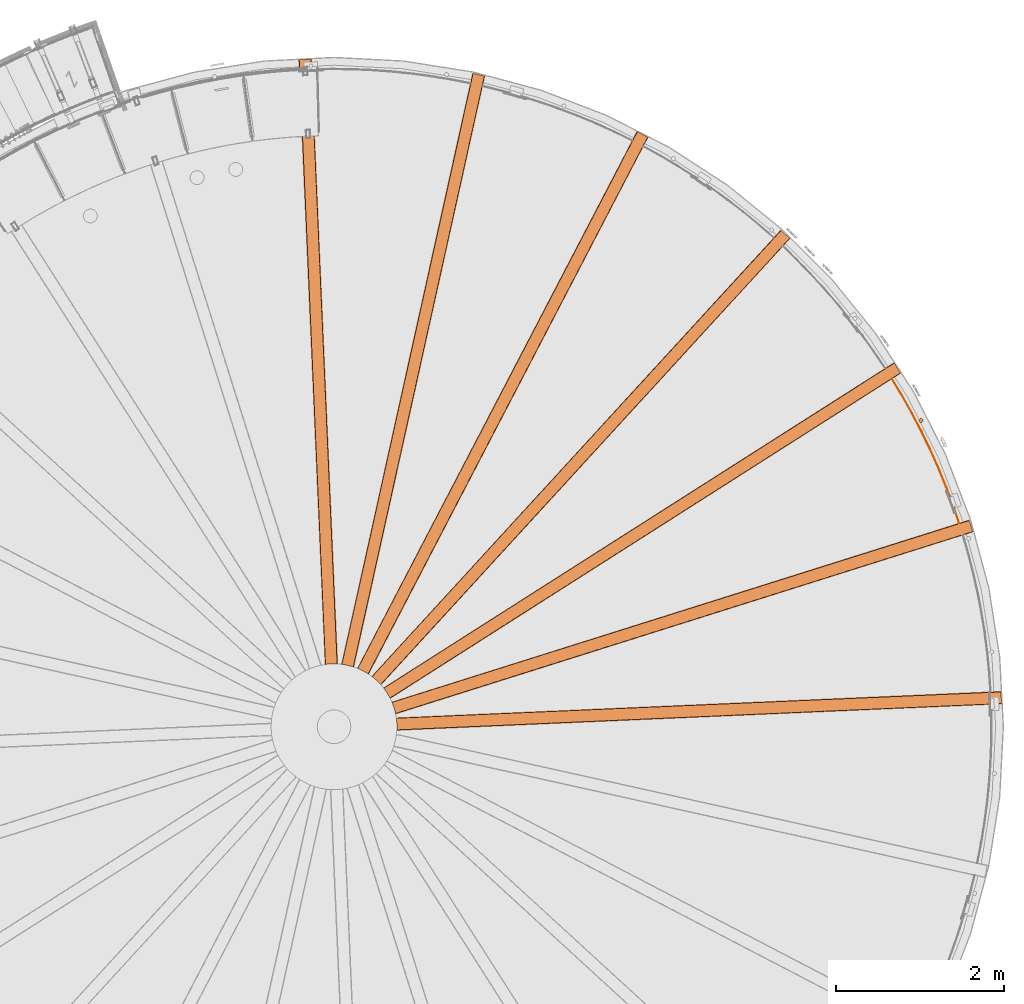
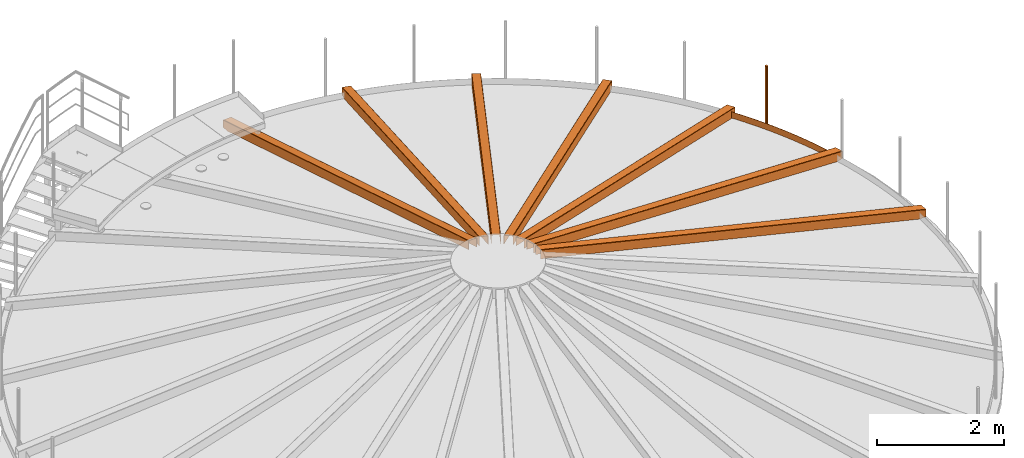
# One storey, part 40 of 126: 9 proxies.
"""IFC2X3 building model written with IfcOpenShell, lengths in millimetres."""

from ifc_helpers import new_model, si_unit, origin, origin_with_axes, place, context, project, spatial, faceted_brep, material, element, save


model = new_model("IFC2X3")

# Units and contexts
context_of_model_1 = context(None, 3, precision=0.1, world=origin())
context_of_model_2 = context(None, 3, precision=0.1, world=origin())
ifc_project = project(units=[si_unit("LENGTHUNIT", "METRE", prefix="MILLI"), si_unit("AREAUNIT", "SQUARE_METRE", prefix="CENTI"), si_unit("VOLUMEUNIT", "CUBIC_METRE", prefix="CENTI"), si_unit("MASSUNIT", "GRAM", prefix="KILO")], contexts=[context_of_model_1, context_of_model_2])

# Site, building, storey
site_placement = place(None, origin_with_axes())
site = spatial("IfcSite", under=ifc_project, at=site_placement, CompositionType="ELEMENT")
building_placement = place(site_placement, origin_with_axes())
building = spatial("IfcBuilding", under=site, at=building_placement, CompositionType="ELEMENT")
storey_placement = place(building_placement, origin_with_axes())
storey = spatial("IfcBuildingStorey", under=building, at=storey_placement, CompositionType="ELEMENT")

# Proxies
ifc_material = material(Name="STAHL")
proxy_1_placement = place(storey_placement, origin_with_axes())
element("IfcBuildingElementProxy", 1, at=proxy_1_placement, inside=storey, material=ifc_material, Name="profile", context=context_of_model_2, shape_type="Brep", body=[
    faceted_brep([(14992.9, 11631.8, 11706.0), (14992.9, 11631.8, 10506.0), (14998.6, 11630.7, 10506.0), (14998.6, 11630.7, 11706.0), (15004.4, 11631.1, 10506.0), (15004.4, 11631.1, 11706.0), (15010.0, 11632.8, 10506.0), (15010.0, 11632.8, 11706.0), (15015.0, 11635.9, 10506.0), (15015.0, 11635.9, 11706.0), (15019.1, 11640.0, 10506.0), (15019.1, 11640.0, 11706.0), (15022.1, 11645.0, 10506.0), (15022.1, 11645.0, 11706.0), (15023.8, 11650.5, 10506.0), (15023.8, 11650.5, 11706.0), (15024.2, 11656.3, 10506.0), (15024.2, 11656.3, 11706.0), (15023.1, 11662.1, 10506.0), (15023.1, 11662.1, 11706.0), (15020.7, 11667.4, 10506.0), (15020.7, 11667.4, 11706.0), (15017.1, 11671.9, 10506.0), (15017.1, 11671.9, 11706.0), (15012.5, 11675.5, 10506.0), (15012.5, 11675.5, 11706.0), (15007.2, 11677.9, 10506.0), (15007.2, 11677.9, 11706.0), (15001.5, 11679.0, 11706.0), (15001.5, 11679.0, 10506.0), (14995.7, 11678.6, 10506.0), (14995.7, 11678.6, 11706.0), (14990.1, 11676.9, 10506.0), (14990.1, 11676.9, 11706.0), (14985.1, 11673.8, 10506.0), (14985.1, 11673.8, 11706.0), (14981.0, 11669.7, 10506.0), (14981.0, 11669.7, 11706.0), (14978.0, 11664.7, 10506.0), (14978.0, 11664.7, 11706.0), (14976.3, 11659.2, 10506.0), (14976.3, 11659.2, 11706.0), (14975.9, 11653.4, 10506.0), (14975.9, 11653.4, 11706.0), (14977.0, 11647.6, 10506.0), (14977.0, 11647.6, 11706.0), (14979.4, 11642.3, 10506.0), (14979.4, 11642.3, 11706.0), (14983.0, 11637.7, 10506.0), (14983.0, 11637.7, 11706.0), (14987.6, 11634.2, 10506.0), (14987.6, 11634.2, 11706.0)], [[[0, 1, 2, 3]], [[3, 2, 4, 5]], [[5, 4, 6, 7]], [[7, 6, 8, 9]], [[9, 8, 10, 11]], [[11, 10, 12, 13]], [[13, 12, 14, 15]], [[15, 14, 16, 17]], [[17, 16, 18, 19]], [[19, 18, 20, 21]], [[21, 20, 22, 23]], [[23, 22, 24, 25]], [[25, 24, 26, 27]], [[28, 27, 26, 29]], [[28, 29, 30, 31]], [[31, 30, 32, 33]], [[33, 32, 34, 35]], [[35, 34, 36, 37]], [[37, 36, 38, 39]], [[39, 38, 40, 41]], [[41, 40, 42, 43]], [[43, 42, 44, 45]], [[45, 44, 46, 47]], [[47, 46, 48, 49]], [[49, 48, 50, 51]], [[51, 50, 1, 0]], [[3, 5, 7, 9, 11, 13, 15, 17, 19, 21, 23, 25, 27, 28, 31, 33, 35, 37, 39, 41, 43, 45, 47, 49, 51, 0]], [[2, 1, 50, 48, 46, 44, 42, 40, 38, 36, 34, 32, 30, 29, 26, 24, 22, 20, 18, 16, 14, 12, 10, 8, 6, 4]]]),
])
proxy_2_placement = place(storey_placement, origin_with_axes())
element("IfcBuildingElementProxy", 2, at=proxy_2_placement, inside=storey, material=ifc_material, Name="profile", context=context_of_model_2, shape_type="Brep", body=[
    faceted_brep([(8753.7, 7961.6, 12406.3), (8753.7, 7961.6, 12574.0), (8753.8, 7961.7, 12575.4), (8753.8, 7962.1, 12576.8), (8753.8, 7962.8, 12578.2), (8753.9, 7963.7, 12579.5), (8753.9, 7964.8, 12580.5), (8754.0, 7966.1, 12581.3), (8754.1, 7967.8, 12581.9), (8754.2, 7969.6, 12582.1), (8754.3, 8037.7, 12581.2), (8748.5, 8103.5, 12582.0), (8748.4, 8104.4, 12582.0), (8748.3, 8105.3, 12581.8), (8748.0, 8106.9, 12581.3), (8747.8, 8108.4, 12580.4), (8747.7, 8109.6, 12579.2), (8747.5, 8110.5, 12577.8), (8747.4, 8111.2, 12576.0), (8747.4, 8111.5, 12573.9), (8747.4, 8111.5, 12406.2), (8748.0, 8107.5, 12406.1), (8748.0, 8107.5, 12573.8), (8748.0, 8107.4, 12574.5), (8748.0, 8107.3, 12575.2), (8748.0, 8106.9, 12576.0), (8748.1, 8106.5, 12576.6), (8748.2, 8105.9, 12577.1), (8748.3, 8105.3, 12577.5), (8748.4, 8104.5, 12577.8), (8748.5, 8103.5, 12577.9), (8754.3, 8037.7, 12577.1), (8754.2, 7969.6, 12577.9), (8754.1, 7969.2, 12577.9), (8754.1, 7968.8, 12577.8), (8754.1, 7967.9, 12577.6), (8754.0, 7967.2, 12577.1), (8754.0, 7966.6, 12576.5), (8754.0, 7966.1, 12575.8), (8754.0, 7965.8, 12574.9), (8754.0, 7965.6, 12573.9), (8754.0, 7965.6, 12406.2), (15960.7, 8276.3, 10641.0), (15960.7, 8276.3, 10506.0), (15960.6, 8280.3, 10506.0), (15960.6, 8280.3, 10641.0), (15960.6, 8280.4, 10641.8), (15960.6, 8280.6, 10642.6), (15960.5, 8281.0, 10643.5), (15960.5, 8281.7, 10644.2), (15960.5, 8282.5, 10644.7), (15960.4, 8283.3, 10645.1), (15960.4, 8284.3, 10645.2), (15954.5, 8418.1, 10645.2), (15954.5, 8418.9, 10645.1), (15954.5, 8419.7, 10644.9), (15954.4, 8420.5, 10644.4), (15954.4, 8421.2, 10643.7), (15954.4, 8421.7, 10642.9), (15954.4, 8422.0, 10642.0), (15954.4, 8422.1, 10641.0), (15954.4, 8422.1, 10506.0), (15954.2, 8426.1, 10506.0), (15954.2, 8426.1, 10641.0), (15954.2, 8426.0, 10642.6), (15954.2, 8425.5, 10644.2), (15954.3, 8424.6, 10645.9), (15954.3, 8423.3, 10647.3), (15954.4, 8421.8, 10648.4), (15954.5, 8420.0, 10649.1), (15954.5, 8418.1, 10649.3), (15960.4, 8284.3, 10649.3), (15960.5, 8282.7, 10649.2), (15960.5, 8281.2, 10648.7), (15960.6, 8279.6, 10647.7), (15960.7, 8278.2, 10646.4), (15960.7, 8277.2, 10644.8), (15960.7, 8276.5, 10643.0), (15838.7, 8275.0, 10506.0), (15838.9, 8271.0, 10506.0), (15832.3, 8420.8, 10506.0), (15832.5, 8416.8, 10506.0)], [[[0, 1, 2, 3, 4, 5, 6, 7, 8, 9, 10, 11, 12, 13, 14, 15, 16, 17, 18, 19, 20, 21, 22, 23, 24, 25, 26, 27, 28, 29, 30, 31, 32, 33, 34, 35, 36, 37, 38, 39, 40, 41]], [[42, 43, 44, 45, 46, 47, 48, 49, 50, 51, 52, 53, 54, 55, 56, 57, 58, 59, 60, 61, 62, 63, 64, 65, 66, 67, 68, 69, 70, 71, 72, 73, 74, 75, 76, 77]], [[41, 78, 79, 0]], [[1, 0, 79, 43, 42, 77, 2]], [[2, 77, 76, 4, 3]], [[4, 76, 75, 5]], [[5, 75, 74, 6]], [[7, 6, 74, 73]], [[8, 7, 73, 72]], [[8, 72, 71, 70, 69, 13, 12, 11, 10, 9]], [[14, 13, 69, 68]], [[15, 14, 68, 67]], [[16, 15, 67, 66]], [[17, 16, 66, 65]], [[18, 17, 65, 64]], [[18, 64, 63, 62, 80, 20, 19]], [[21, 20, 80, 81]], [[61, 81, 80, 62]], [[44, 43, 79, 78]], [[40, 39, 46, 45, 44, 78, 41]], [[39, 38, 47, 46]], [[38, 37, 48, 47]], [[37, 36, 49, 48]], [[36, 35, 50, 49]], [[35, 34, 51, 50]], [[34, 33, 32, 31, 30, 29, 54, 53, 52, 51]], [[29, 28, 55, 54]], [[28, 27, 56, 55]], [[26, 57, 56, 27]], [[25, 58, 57, 26]], [[25, 24, 23, 59, 58]], [[23, 22, 21, 81, 61, 60, 59]]]),
])
proxy_3_placement = place(storey_placement, origin_with_axes())
element("IfcBuildingElementProxy", 3, at=proxy_3_placement, inside=storey, material=ifc_material, Name="profile", context=context_of_model_2, shape_type="Brep", body=[
    faceted_brep([(8739.5, 8156.9, 12406.3), (8739.5, 8156.9, 12574.0), (8739.4, 8157.0, 12575.4), (8739.4, 8157.4, 12576.8), (8739.2, 8158.0, 12578.2), (8739.0, 8158.9, 12579.5), (8738.8, 8160.0, 12580.5), (8738.5, 8161.3, 12581.3), (8738.2, 8162.9, 12581.9), (8737.8, 8164.7, 12582.1), (8720.3, 8230.5, 12581.2), (8697.7, 8292.6, 12582.0), (8697.3, 8293.4, 12582.0), (8697.0, 8294.3, 12581.8), (8696.3, 8295.8, 12581.3), (8695.8, 8297.1, 12580.4), (8695.3, 8298.2, 12579.2), (8694.9, 8299.1, 12577.8), (8694.6, 8299.8, 12576.0), (8694.5, 8300.0, 12573.9), (8694.5, 8300.0, 12406.2), (8696.1, 8296.3, 12406.1), (8696.1, 8296.3, 12573.8), (8696.1, 8296.2, 12574.5), (8696.2, 8296.1, 12575.2), (8696.3, 8295.8, 12576.0), (8696.5, 8295.3, 12576.6), (8696.7, 8294.8, 12577.1), (8697.0, 8294.2, 12577.5), (8697.3, 8293.5, 12577.8), (8697.7, 8292.6, 12577.9), (8720.3, 8230.5, 12577.1), (8737.8, 8164.7, 12577.9), (8737.9, 8164.3, 12577.9), (8738.0, 8163.9, 12577.8), (8738.2, 8163.1, 12577.6), (8738.3, 8162.3, 12577.1), (8738.4, 8161.8, 12576.5), (8738.5, 8161.3, 12575.8), (8738.6, 8160.9, 12574.9), (8738.6, 8160.8, 12573.9), (8738.6, 8160.8, 12406.2), (15619.4, 10326.1, 10641.0), (15619.4, 10326.1, 10506.0), (15618.2, 10330.0, 10506.0), (15618.2, 10330.0, 10641.0), (15618.2, 10330.0, 10641.8), (15618.1, 10330.2, 10642.6), (15618.0, 10330.7, 10643.5), (15617.8, 10331.3, 10644.2), (15617.6, 10332.0, 10644.7), (15617.3, 10332.9, 10645.1), (15617.0, 10333.8, 10645.2), (15576.7, 10461.6, 10645.2), (15576.5, 10462.3, 10645.1), (15576.3, 10463.0, 10644.9), (15576.0, 10463.8, 10644.4), (15575.8, 10464.5, 10643.7), (15575.7, 10465.0, 10642.9), (15575.6, 10465.3, 10642.0), (15575.5, 10465.4, 10641.0), (15575.5, 10465.4, 10506.0), (15574.3, 10469.2, 10506.0), (15574.3, 10469.2, 10641.0), (15574.4, 10469.0, 10642.6), (15574.5, 10468.6, 10644.2), (15574.8, 10467.7, 10645.9), (15575.2, 10466.5, 10647.3), (15575.6, 10465.0, 10648.4), (15576.2, 10463.3, 10649.1), (15576.7, 10461.6, 10649.3), (15617.0, 10333.8, 10649.3), (15617.5, 10332.3, 10649.2), (15618.0, 10330.8, 10648.7), (15618.4, 10329.3, 10647.7), (15618.9, 10328.0, 10646.4), (15619.2, 10327.0, 10644.8), (15619.4, 10326.3, 10643.0), (15501.9, 10293.3, 10506.0), (15503.1, 10289.5, 10506.0), (15458.0, 10432.5, 10506.0), (15459.2, 10428.7, 10506.0)], [[[0, 1, 2, 3, 4, 5, 6, 7, 8, 9, 10, 11, 12, 13, 14, 15, 16, 17, 18, 19, 20, 21, 22, 23, 24, 25, 26, 27, 28, 29, 30, 31, 32, 33, 34, 35, 36, 37, 38, 39, 40, 41]], [[42, 43, 44, 45, 46, 47, 48, 49, 50, 51, 52, 53, 54, 55, 56, 57, 58, 59, 60, 61, 62, 63, 64, 65, 66, 67, 68, 69, 70, 71, 72, 73, 74, 75, 76, 77]], [[41, 78, 79, 0]], [[1, 0, 79, 43, 42, 77, 2]], [[2, 77, 76, 4, 3]], [[4, 76, 75, 5]], [[5, 75, 74, 6]], [[7, 6, 74, 73]], [[8, 7, 73, 72]], [[8, 72, 71, 70, 69, 13, 12, 11, 10, 9]], [[14, 13, 69, 68]], [[15, 14, 68, 67]], [[16, 15, 67, 66]], [[17, 16, 66, 65]], [[18, 17, 65, 64]], [[18, 64, 63, 62, 80, 20, 19]], [[21, 20, 80, 81]], [[61, 81, 80, 62]], [[44, 43, 79, 78]], [[41, 40, 39, 46, 45, 44, 78]], [[39, 38, 47, 46]], [[38, 37, 48, 47]], [[37, 36, 49, 48]], [[36, 35, 50, 49]], [[35, 34, 51, 50]], [[34, 33, 32, 31, 30, 29, 54, 53, 52, 51]], [[29, 28, 55, 54]], [[28, 27, 56, 55]], [[26, 57, 56, 27]], [[25, 58, 57, 26]], [[25, 24, 23, 59, 58]], [[23, 22, 21, 81, 61, 60, 59]]]),
])
proxy_4_placement = place(storey_placement, origin_with_axes())
element("IfcBuildingElementProxy", 4, at=proxy_4_placement, inside=storey, material=ifc_material, Name="profile", context=context_of_model_2, shape_type="Brep", body=[
    faceted_brep([(8675.1, 8341.8, 12406.3), (8675.1, 8341.8, 12574.0), (8675.1, 8341.9, 12575.4), (8674.9, 8342.2, 12576.8), (8674.6, 8342.8, 12578.2), (8674.2, 8343.7, 12579.5), (8673.7, 8344.6, 12580.5), (8673.1, 8345.8, 12581.3), (8672.3, 8347.3, 12581.9), (8671.5, 8349.0, 12582.1), (8637.5, 8408.0, 12581.2), (8599.6, 8462.1, 12582.0), (8599.1, 8462.8, 12582.0), (8598.5, 8463.5, 12581.8), (8597.5, 8464.8, 12581.3), (8596.6, 8466.0, 12580.4), (8595.9, 8466.9, 12579.2), (8595.3, 8467.7, 12577.8), (8594.9, 8468.2, 12576.0), (8594.7, 8468.4, 12573.9), (8594.7, 8468.4, 12406.2), (8597.2, 8465.3, 12406.1), (8597.2, 8465.3, 12573.8), (8597.2, 8465.2, 12574.5), (8597.3, 8465.1, 12575.2), (8597.5, 8464.8, 12576.0), (8597.8, 8464.4, 12576.6), (8598.1, 8464.0, 12577.1), (8598.6, 8463.5, 12577.5), (8599.1, 8462.8, 12577.8), (8599.6, 8462.1, 12577.9), (8637.5, 8408.0, 12577.1), (8671.5, 8349.0, 12577.9), (8671.7, 8348.6, 12577.9), (8671.9, 8348.2, 12577.8), (8672.3, 8347.4, 12577.6), (8672.6, 8346.8, 12577.1), (8672.9, 8346.2, 12576.5), (8673.1, 8345.8, 12575.8), (8673.2, 8345.5, 12574.9), (8673.3, 8345.4, 12573.9), (8673.3, 8345.4, 12406.2), (14759.2, 12217.8, 10641.0), (14759.2, 12217.8, 10506.0), (14757.1, 12221.2, 10506.0), (14757.1, 12221.2, 10641.0), (14757.0, 12221.2, 10641.8), (14756.9, 12221.4, 10642.6), (14756.7, 12221.8, 10643.5), (14756.3, 12222.4, 10644.2), (14755.9, 12223.0, 10644.7), (14755.4, 12223.8, 10645.1), (14754.9, 12224.6, 10645.2), (14682.9, 12337.6, 10645.2), (14682.5, 12338.2, 10645.1), (14682.1, 12338.9, 10644.9), (14681.7, 12339.6, 10644.4), (14681.3, 12340.1, 10643.7), (14681.0, 12340.6, 10642.9), (14680.8, 12340.8, 10642.0), (14680.8, 12340.9, 10641.0), (14680.8, 12340.9, 10506.0), (14678.6, 12344.3, 10506.0), (14678.6, 12344.3, 10641.0), (14678.7, 12344.2, 10642.6), (14679.0, 12343.8, 10644.2), (14679.5, 12343.0, 10645.9), (14680.1, 12342.0, 10647.3), (14681.0, 12340.6, 10648.4), (14681.9, 12339.1, 10649.1), (14682.9, 12337.6, 10649.3), (14754.9, 12224.6, 10649.3), (14755.8, 12223.2, 10649.2), (14756.6, 12222.0, 10648.7), (14757.5, 12220.6, 10647.7), (14758.2, 12219.4, 10646.4), (14758.8, 12218.5, 10644.8), (14759.1, 12218.0, 10643.0), (14654.2, 12155.6, 10506.0), (14656.4, 12152.3, 10506.0), (14575.8, 12278.8, 10506.0), (14577.9, 12275.4, 10506.0)], [[[0, 1, 2, 3, 4, 5, 6, 7, 8, 9, 10, 11, 12, 13, 14, 15, 16, 17, 18, 19, 20, 21, 22, 23, 24, 25, 26, 27, 28, 29, 30, 31, 32, 33, 34, 35, 36, 37, 38, 39, 40, 41]], [[42, 43, 44, 45, 46, 47, 48, 49, 50, 51, 52, 53, 54, 55, 56, 57, 58, 59, 60, 61, 62, 63, 64, 65, 66, 67, 68, 69, 70, 71, 72, 73, 74, 75, 76, 77]], [[41, 78, 79, 0]], [[1, 0, 79, 43, 42, 77, 2]], [[2, 77, 76, 4, 3]], [[4, 76, 75, 5]], [[5, 75, 74, 6]], [[7, 6, 74, 73]], [[8, 7, 73, 72]], [[8, 72, 71, 70, 69, 13, 12, 11, 10, 9]], [[14, 13, 69, 68]], [[15, 14, 68, 67]], [[16, 15, 67, 66]], [[17, 16, 66, 65]], [[18, 17, 65, 64]], [[18, 64, 63, 62, 80, 20, 19]], [[21, 20, 80, 81]], [[61, 81, 80, 62]], [[44, 43, 79, 78]], [[40, 39, 46, 45, 44, 78, 41]], [[39, 38, 47, 46]], [[38, 37, 48, 47]], [[37, 36, 49, 48]], [[36, 35, 50, 49]], [[35, 34, 51, 50]], [[34, 33, 32, 31, 30, 29, 54, 53, 52, 51]], [[29, 28, 55, 54]], [[28, 27, 56, 55]], [[26, 57, 56, 27]], [[25, 58, 57, 26]], [[25, 24, 23, 59, 58]], [[23, 22, 21, 81, 61, 60, 59]]]),
])
proxy_5_placement = place(storey_placement, origin_with_axes())
element("IfcBuildingElementProxy", 5, at=proxy_5_placement, inside=storey, material=ifc_material, Name="profile", context=context_of_model_2, shape_type="Brep", body=[
    faceted_brep([(8565.1, 8503.8, 12406.3), (8565.1, 8503.8, 12574.0), (8565.0, 8503.9, 12575.4), (8564.8, 8504.1, 12576.8), (8564.3, 8504.6, 12578.2), (8563.7, 8505.3, 12579.5), (8563.0, 8506.1, 12580.5), (8562.1, 8507.1, 12581.3), (8561.0, 8508.4, 12581.9), (8559.7, 8509.7, 12582.1), (8511.7, 8558.0, 12581.2), (8461.1, 8600.4, 12582.0), (8460.4, 8600.9, 12582.0), (8459.6, 8601.5, 12581.8), (8458.3, 8602.5, 12581.3), (8457.2, 8603.4, 12580.4), (8456.2, 8604.1, 12579.2), (8455.4, 8604.7, 12577.8), (8454.9, 8605.1, 12576.0), (8454.7, 8605.3, 12573.9), (8454.7, 8605.3, 12406.2), (8457.9, 8602.8, 12406.1), (8457.9, 8602.8, 12573.8), (8457.9, 8602.8, 12574.5), (8458.1, 8602.7, 12575.2), (8458.3, 8602.5, 12576.0), (8458.7, 8602.2, 12576.6), (8459.1, 8601.9, 12577.1), (8459.7, 8601.5, 12577.5), (8460.3, 8601.0, 12577.8), (8461.1, 8600.4, 12577.9), (8511.7, 8558.0, 12577.1), (8559.7, 8509.7, 12577.9), (8560.0, 8509.4, 12577.9), (8560.3, 8509.1, 12577.8), (8560.9, 8508.5, 12577.6), (8561.4, 8507.9, 12577.1), (8561.8, 8507.5, 12576.5), (8562.1, 8507.1, 12575.8), (8562.3, 8506.9, 12574.9), (8562.4, 8506.8, 12573.9), (8562.4, 8506.8, 12406.2), (13438.7, 13822.4, 10641.0), (13438.7, 13822.4, 10506.0), (13435.8, 13825.1, 10506.0), (13435.8, 13825.1, 10641.0), (13435.7, 13825.1, 10641.8), (13435.6, 13825.3, 10642.6), (13435.2, 13825.6, 10643.5), (13434.7, 13826.0, 10644.2), (13434.2, 13826.6, 10644.7), (13433.5, 13827.2, 10645.1), (13432.8, 13827.8, 10645.2), (13334.0, 13918.3, 10645.2), (13333.5, 13918.8, 10645.1), (13332.9, 13919.4, 10644.9), (13332.3, 13919.9, 10644.4), (13331.8, 13920.4, 10643.7), (13331.4, 13920.7, 10642.9), (13331.2, 13920.9, 10642.0), (13331.1, 13921.0, 10641.0), (13331.1, 13921.0, 10506.0), (13328.1, 13923.7, 10506.0), (13328.1, 13923.7, 10641.0), (13328.3, 13923.6, 10642.6), (13328.6, 13923.3, 10644.2), (13329.3, 13922.7, 10645.9), (13330.2, 13921.8, 10647.3), (13331.4, 13920.8, 10648.4), (13332.7, 13919.6, 10649.1), (13334.0, 13918.3, 10649.3), (13432.8, 13827.8, 10649.3), (13434.0, 13826.7, 10649.2), (13435.1, 13825.7, 10648.7), (13436.3, 13824.6, 10647.7), (13437.3, 13823.7, 10646.4), (13438.1, 13823.0, 10644.8), (13438.6, 13822.5, 10643.0), (13353.4, 13735.2, 10506.0), (13356.3, 13732.5, 10506.0), (13245.7, 13833.8, 10506.0), (13248.7, 13831.1, 10506.0)], [[[0, 1, 2, 3, 4, 5, 6, 7, 8, 9, 10, 11, 12, 13, 14, 15, 16, 17, 18, 19, 20, 21, 22, 23, 24, 25, 26, 27, 28, 29, 30, 31, 32, 33, 34, 35, 36, 37, 38, 39, 40, 41]], [[42, 43, 44, 45, 46, 47, 48, 49, 50, 51, 52, 53, 54, 55, 56, 57, 58, 59, 60, 61, 62, 63, 64, 65, 66, 67, 68, 69, 70, 71, 72, 73, 74, 75, 76, 77]], [[41, 78, 79, 0]], [[0, 79, 43, 42, 77, 2, 1]], [[2, 77, 76, 75, 5, 4, 3]], [[5, 75, 74, 6]], [[7, 6, 74, 73]], [[8, 7, 73, 72]], [[8, 72, 71, 70, 69, 13, 12, 11, 10, 9]], [[14, 13, 69, 68]], [[15, 14, 68, 67]], [[16, 15, 67, 66]], [[16, 66, 65, 64, 18, 17]], [[18, 64, 63, 62, 80, 20, 19]], [[21, 20, 80, 81]], [[61, 81, 80, 62]], [[44, 43, 79, 78]], [[40, 39, 46, 45, 44, 78, 41]], [[39, 38, 37, 48, 47, 46]], [[37, 36, 49, 48]], [[36, 35, 50, 49]], [[35, 34, 51, 50]], [[34, 33, 32, 31, 30, 29, 54, 53, 52, 51]], [[29, 28, 55, 54]], [[28, 27, 56, 55]], [[26, 57, 56, 27]], [[26, 25, 24, 23, 59, 58, 57]], [[23, 22, 21, 81, 61, 60, 59]]]),
])
proxy_6_placement = place(storey_placement, origin_with_axes())
element("IfcBuildingElementProxy", 6, at=proxy_6_placement, inside=storey, material=ifc_material, Name="profile", context=context_of_model_2, shape_type="Brep", body=[
    faceted_brep([(8416.9, 8631.7, 12406.3), (8416.9, 8631.7, 12574.0), (8416.8, 8631.8, 12575.4), (8416.5, 8632.0, 12576.8), (8416.0, 8632.4, 12578.2), (8415.2, 8632.9, 12579.5), (8414.3, 8633.5, 12580.5), (8413.2, 8634.2, 12581.3), (8411.8, 8635.1, 12581.9), (8410.2, 8636.1, 12582.1), (8351.3, 8670.3, 12581.2), (8291.4, 8698.2, 12582.0), (8290.6, 8698.5, 12582.0), (8289.8, 8698.8, 12581.8), (8288.2, 8699.5, 12581.3), (8286.9, 8700.0, 12580.4), (8285.8, 8700.5, 12579.2), (8284.9, 8700.8, 12577.8), (8284.2, 8701.1, 12576.0), (8284.0, 8701.2, 12573.9), (8284.0, 8701.2, 12406.2), (8287.7, 8699.7, 12406.1), (8287.7, 8699.7, 12573.8), (8287.8, 8699.7, 12574.5), (8287.9, 8699.6, 12575.2), (8288.2, 8699.5, 12576.0), (8288.7, 8699.3, 12576.6), (8289.2, 8699.1, 12577.1), (8289.8, 8698.8, 12577.5), (8290.6, 8698.5, 12577.8), (8291.4, 8698.2, 12577.9), (8351.3, 8670.3, 12577.1), (8410.2, 8636.1, 12577.9), (8410.6, 8635.9, 12577.9), (8411.0, 8635.6, 12577.8), (8411.6, 8635.2, 12577.6), (8412.3, 8634.8, 12577.1), (8412.8, 8634.5, 12576.5), (8413.2, 8634.2, 12575.8), (8413.5, 8634.0, 12574.9), (8413.6, 8633.9, 12573.9), (8413.6, 8633.9, 12406.2), (11747.9, 15030.5, 10641.0), (11747.9, 15030.5, 10506.0), (11744.4, 15032.4, 10506.0), (11744.4, 15032.4, 10641.0), (11744.3, 15032.4, 10641.8), (11744.1, 15032.5, 10642.6), (11743.7, 15032.7, 10643.5), (11743.1, 15033.0, 10644.2), (11742.4, 15033.4, 10644.7), (11741.7, 15033.8, 10645.1), (11740.8, 15034.2, 10645.2), (11622.0, 15096.1, 10645.2), (11621.3, 15096.4, 10645.1), (11620.6, 15096.8, 10644.9), (11619.9, 15097.2, 10644.4), (11619.3, 15097.5, 10643.7), (11618.8, 15097.7, 10642.9), (11618.5, 15097.9, 10642.0), (11618.4, 15097.9, 10641.0), (11618.4, 15097.9, 10506.0), (11614.9, 15099.8, 10506.0), (11614.9, 15099.8, 10641.0), (11615.0, 15099.7, 10642.6), (11615.4, 15099.5, 10644.2), (11616.2, 15099.1, 10645.9), (11617.4, 15098.5, 10647.3), (11618.8, 15097.8, 10648.4), (11620.3, 15096.9, 10649.1), (11622.0, 15096.1, 10649.3), (11740.8, 15034.2, 10649.3), (11742.2, 15033.5, 10649.2), (11743.6, 15032.8, 10648.7), (11745.0, 15032.0, 10647.7), (11746.2, 15031.4, 10646.4), (11747.2, 15030.9, 10644.8), (11747.7, 15030.6, 10643.0), (11688.1, 14924.2, 10506.0), (11691.6, 14922.3, 10506.0), (11558.6, 14991.6, 10506.0), (11562.1, 14989.7, 10506.0)], [[[0, 1, 2, 3, 4, 5, 6, 7, 8, 9, 10, 11, 12, 13, 14, 15, 16, 17, 18, 19, 20, 21, 22, 23, 24, 25, 26, 27, 28, 29, 30, 31, 32, 33, 34, 35, 36, 37, 38, 39, 40, 41]], [[42, 43, 44, 45, 46, 47, 48, 49, 50, 51, 52, 53, 54, 55, 56, 57, 58, 59, 60, 61, 62, 63, 64, 65, 66, 67, 68, 69, 70, 71, 72, 73, 74, 75, 76, 77]], [[41, 78, 79, 0]], [[1, 0, 79, 43, 42, 77, 2]], [[2, 77, 76, 4, 3]], [[4, 76, 75, 5]], [[5, 75, 74, 6]], [[7, 6, 74, 73]], [[8, 7, 73, 72]], [[8, 72, 71, 70, 69, 13, 12, 11, 10, 9]], [[14, 13, 69, 68]], [[15, 14, 68, 67]], [[16, 15, 67, 66]], [[17, 16, 66, 65]], [[18, 17, 65, 64]], [[18, 64, 63, 62, 80, 20, 19]], [[21, 20, 80, 81]], [[61, 81, 80, 62]], [[44, 43, 79, 78]], [[40, 39, 46, 45, 44, 78, 41]], [[39, 38, 47, 46]], [[38, 37, 48, 47]], [[37, 36, 49, 48]], [[36, 35, 50, 49]], [[35, 34, 51, 50]], [[34, 33, 32, 31, 30, 29, 54, 53, 52, 51]], [[29, 28, 55, 54]], [[28, 27, 56, 55]], [[26, 57, 56, 27]], [[25, 58, 57, 26]], [[25, 24, 23, 59, 58]], [[22, 21, 81, 61, 60, 59, 23]]]),
])
proxy_7_placement = place(storey_placement, origin_with_axes())
element("IfcBuildingElementProxy", 7, at=proxy_7_placement, inside=storey, material=ifc_material, Name="profile", context=context_of_model_2, shape_type="Brep", body=[
    faceted_brep([(8240.6, 8717.0, 12575.4), (8240.2, 8717.2, 12576.8), (8239.6, 8717.4, 12578.2), (8238.7, 8717.7, 12579.5), (8237.7, 8718.0, 12580.5), (8236.4, 8718.4, 12581.3), (8234.8, 8718.9, 12581.9), (8233.0, 8719.5, 12582.1), (8167.3, 8737.2, 12581.2), (8102.3, 8748.7, 12582.0), (8101.4, 8748.8, 12582.0), (8100.5, 8748.9, 12581.8), (8098.9, 8749.1, 12581.3), (8097.4, 8749.3, 12580.4), (8096.2, 8749.4, 12579.2), (8095.2, 8749.6, 12577.8), (8094.5, 8749.6, 12576.0), (8094.3, 8749.7, 12573.9), (8094.3, 8749.7, 12406.2), (8098.3, 8749.2, 12406.1), (8098.3, 8749.2, 12573.8), (8098.3, 8749.2, 12574.5), (8098.5, 8749.1, 12575.2), (8098.9, 8749.1, 12576.0), (8099.3, 8749.0, 12576.6), (8099.9, 8749.0, 12577.1), (8100.5, 8748.9, 12577.5), (8101.3, 8748.8, 12577.8), (8102.3, 8748.7, 12577.9), (8167.3, 8737.2, 12577.1), (8233.0, 8719.5, 12577.9), (8233.5, 8719.4, 12577.9), (8233.9, 8719.2, 12577.8), (8234.7, 8719.0, 12577.6), (8235.4, 8718.7, 12577.1), (8236.0, 8718.6, 12576.5), (8236.4, 8718.4, 12575.8), (8236.7, 8718.3, 12574.9), (8236.9, 8718.3, 12573.9), (8236.9, 8718.3, 12406.2), (8240.7, 8717.0, 12406.3), (8240.7, 8717.0, 12574.0), (9801.8, 15759.9, 10643.0), (9802.1, 15759.9, 10641.0), (9802.1, 15759.9, 10506.0), (9798.2, 15760.7, 10506.0), (9798.2, 15760.7, 10641.0), (9798.1, 15760.7, 10641.8), (9797.9, 15760.8, 10642.6), (9797.4, 15760.9, 10643.5), (9796.8, 15761.0, 10644.2), (9796.0, 15761.2, 10644.7), (9795.2, 15761.4, 10645.1), (9794.2, 15761.6, 10645.2), (9663.4, 15790.6, 10645.2), (9662.7, 15790.8, 10645.1), (9661.9, 15790.9, 10644.9), (9661.1, 15791.1, 10644.4), (9660.5, 15791.3, 10643.7), (9659.9, 15791.4, 10642.9), (9659.6, 15791.4, 10642.0), (9659.5, 15791.5, 10641.0), (9659.5, 15791.5, 10506.0), (9655.6, 15792.3, 10506.0), (9655.6, 15792.3, 10641.0), (9655.8, 15792.3, 10642.6), (9656.2, 15792.2, 10644.2), (9657.1, 15792.0, 10645.9), (9658.4, 15791.7, 10647.3), (9659.9, 15791.4, 10648.4), (9661.6, 15791.0, 10649.1), (9663.4, 15790.6, 10649.3), (9794.2, 15761.6, 10649.3), (9795.8, 15761.3, 10649.2), (9797.2, 15760.9, 10648.7), (9798.8, 15760.6, 10647.7), (9800.2, 15760.3, 10646.4), (9801.2, 15760.1, 10644.8), (9771.8, 15641.6, 10506.0), (9775.7, 15640.8, 10506.0), (9629.2, 15673.2, 10506.0), (9633.1, 15672.4, 10506.0)], [[[0, 1, 2, 3, 4, 5, 6, 7, 8, 9, 10, 11, 12, 13, 14, 15, 16, 17, 18, 19, 20, 21, 22, 23, 24, 25, 26, 27, 28, 29, 30, 31, 32, 33, 34, 35, 36, 37, 38, 39, 40, 41]], [[42, 43, 44, 45, 46, 47, 48, 49, 50, 51, 52, 53, 54, 55, 56, 57, 58, 59, 60, 61, 62, 63, 64, 65, 66, 67, 68, 69, 70, 71, 72, 73, 74, 75, 76, 77]], [[39, 78, 79, 40]], [[0, 41, 40, 79, 44, 43, 42]], [[0, 42, 77, 2, 1]], [[2, 77, 76, 3]], [[3, 76, 75, 4]], [[5, 4, 75, 74]], [[6, 5, 74, 73]], [[6, 73, 72, 71, 70, 11, 10, 9, 8, 7]], [[12, 11, 70, 69]], [[13, 12, 69, 68]], [[14, 13, 68, 67]], [[15, 14, 67, 66]], [[16, 15, 66, 65]], [[16, 65, 64, 63, 80, 18, 17]], [[19, 18, 80, 81]], [[62, 81, 80, 63]], [[45, 44, 79, 78]], [[37, 47, 46, 45, 78, 39, 38]], [[37, 36, 48, 47]], [[36, 35, 49, 48]], [[35, 34, 50, 49]], [[34, 33, 51, 50]], [[33, 32, 52, 51]], [[32, 31, 30, 29, 28, 27, 55, 54, 53, 52]], [[27, 26, 56, 55]], [[26, 25, 57, 56]], [[24, 58, 57, 25]], [[23, 59, 58, 24]], [[22, 21, 60, 59, 23]], [[21, 20, 19, 81, 62, 61, 60]]]),
])
proxy_8_placement = place(storey_placement, origin_with_axes())
element("IfcBuildingElementProxy", 8, at=proxy_8_placement, inside=storey, material=ifc_material, Name="profile", context=context_of_model_2, shape_type="Brep", body=[
    faceted_brep([(7898.5, 8747.4, 12573.9), (7898.5, 8747.4, 12406.2), (7902.5, 8748.0, 12406.1), (7902.5, 8748.0, 12573.8), (7902.6, 8748.0, 12574.5), (7902.7, 8748.0, 12575.2), (7903.1, 8748.0, 12576.0), (7903.5, 8748.1, 12576.6), (7904.1, 8748.2, 12577.1), (7904.7, 8748.3, 12577.5), (7905.5, 8748.4, 12577.8), (7906.5, 8748.5, 12577.9), (7972.3, 8754.3, 12577.1), (8040.4, 8754.2, 12577.9), (8040.8, 8754.1, 12577.9), (8041.2, 8754.1, 12577.8), (8042.1, 8754.1, 12577.6), (8042.8, 8754.0, 12577.1), (8043.4, 8754.0, 12576.5), (8043.9, 8754.0, 12575.8), (8044.2, 8754.0, 12574.9), (8044.4, 8754.0, 12573.9), (8044.4, 8754.0, 12406.2), (8048.4, 8753.7, 12406.3), (8048.4, 8753.7, 12574.0), (8048.3, 8753.8, 12575.4), (8047.9, 8753.8, 12576.8), (8047.2, 8753.8, 12578.2), (8046.3, 8753.9, 12579.5), (8045.2, 8753.9, 12580.5), (8043.9, 8754.0, 12581.3), (8042.2, 8754.1, 12581.9), (8040.4, 8754.2, 12582.1), (7972.3, 8754.3, 12581.2), (7906.5, 8748.5, 12582.0), (7905.6, 8748.4, 12582.0), (7904.7, 8748.3, 12581.8), (7903.1, 8748.0, 12581.3), (7901.6, 8747.8, 12580.4), (7900.4, 8747.7, 12579.2), (7899.5, 8747.5, 12577.8), (7898.8, 8747.4, 12576.0), (7583.9, 15954.2, 10506.0), (7583.9, 15954.2, 10641.0), (7584.0, 15954.2, 10642.6), (7584.5, 15954.2, 10644.2), (7585.4, 15954.3, 10645.9), (7586.7, 15954.3, 10647.3), (7588.2, 15954.4, 10648.4), (7590.0, 15954.5, 10649.1), (7591.9, 15954.5, 10649.3), (7725.7, 15960.4, 10649.3), (7727.3, 15960.5, 10649.2), (7728.8, 15960.5, 10648.7), (7730.4, 15960.6, 10647.7), (7731.8, 15960.7, 10646.4), (7732.8, 15960.7, 10644.8), (7733.5, 15960.7, 10643.0), (7733.7, 15960.7, 10641.0), (7733.7, 15960.7, 10506.0), (7729.7, 15960.6, 10506.0), (7729.7, 15960.6, 10641.0), (7729.6, 15960.6, 10641.8), (7729.4, 15960.6, 10642.6), (7729.0, 15960.5, 10643.5), (7728.3, 15960.5, 10644.2), (7727.5, 15960.5, 10644.7), (7726.7, 15960.4, 10645.1), (7725.7, 15960.4, 10645.2), (7591.9, 15954.5, 10645.2), (7591.1, 15954.5, 10645.1), (7590.3, 15954.5, 10644.9), (7589.5, 15954.4, 10644.4), (7588.8, 15954.4, 10643.7), (7588.3, 15954.4, 10642.9), (7588.0, 15954.4, 10642.0), (7587.9, 15954.4, 10641.0), (7587.9, 15954.4, 10506.0), (7735.0, 15838.7, 10506.0), (7739.0, 15838.9, 10506.0), (7589.2, 15832.3, 10506.0), (7593.2, 15832.5, 10506.0)], [[[0, 1, 2, 3, 4, 5, 6, 7, 8, 9, 10, 11, 12, 13, 14, 15, 16, 17, 18, 19, 20, 21, 22, 23, 24, 25, 26, 27, 28, 29, 30, 31, 32, 33, 34, 35, 36, 37, 38, 39, 40, 41]], [[42, 43, 44, 45, 46, 47, 48, 49, 50, 51, 52, 53, 54, 55, 56, 57, 58, 59, 60, 61, 62, 63, 64, 65, 66, 67, 68, 69, 70, 71, 72, 73, 74, 75, 76, 77]], [[22, 78, 79, 23]], [[24, 23, 79, 59, 58, 57, 25]], [[27, 26, 25, 57, 56]], [[27, 56, 55, 28]], [[28, 55, 54, 29]], [[30, 29, 54, 53]], [[31, 30, 53, 52]], [[36, 35, 34, 33, 32, 31, 52, 51, 50, 49]], [[37, 36, 49, 48]], [[38, 37, 48, 47]], [[39, 38, 47, 46]], [[40, 39, 46, 45]], [[41, 40, 45, 44]], [[0, 41, 44, 43, 42, 80, 1]], [[2, 1, 80, 81]], [[77, 81, 80, 42]], [[60, 59, 79, 78]], [[20, 62, 61, 60, 78, 22, 21]], [[20, 19, 63, 62]], [[19, 18, 64, 63]], [[18, 17, 65, 64]], [[17, 16, 66, 65]], [[16, 15, 67, 66]], [[10, 70, 69, 68, 67, 15, 14, 13, 12, 11]], [[10, 9, 71, 70]], [[9, 8, 72, 71]], [[7, 73, 72, 8]], [[6, 74, 73, 7]], [[4, 75, 74, 6, 5]], [[3, 2, 81, 77, 76, 75, 4]]]),
])
proxy_9_placement = place(storey_placement, origin_with_axes())
element("IfcBuildingElementProxy", 9, at=proxy_9_placement, inside=storey, material=ifc_material, Name="profile", context=context_of_model_2, shape_type="Brep", body=[
    faceted_brep([(15459.6, 10432.5, 10636.0), (15459.6, 10432.5, 10516.0), (15382.5, 10657.6, 10516.0), (15298.6, 10880.2, 10516.0), (15208.0, 11100.2, 10516.0), (15110.7, 11317.4, 10516.0), (15007.0, 11531.5, 10516.0), (14896.7, 11742.3, 10516.0), (14780.1, 11949.7, 10516.0), (14657.3, 12153.5, 10516.0), (14657.3, 12153.5, 10636.0), (14780.1, 11949.7, 10636.0), (14896.7, 11742.3, 10636.0), (15007.0, 11531.5, 10636.0), (15110.7, 11317.4, 10636.0), (15208.0, 11100.2, 10636.0), (15298.6, 10880.2, 10636.0), (15382.5, 10657.6, 10636.0), (15454.8, 10431.0, 10636.0), (14653.1, 12150.8, 10636.0), (14775.8, 11947.2, 10636.0), (14892.3, 11739.9, 10636.0), (15002.5, 11529.2, 10636.0), (15106.2, 11315.3, 10636.0), (15203.4, 11098.2, 10636.0), (15293.9, 10878.4, 10636.0), (15377.8, 10655.9, 10636.0), (14653.1, 12150.8, 10516.0), (14775.8, 11947.2, 10516.0), (14892.3, 11739.9, 10516.0), (15002.5, 11529.2, 10516.0), (15106.2, 11315.3, 10516.0), (15203.4, 11098.2, 10516.0), (15293.9, 10878.4, 10516.0), (15377.8, 10655.9, 10516.0), (15454.8, 10431.0, 10516.0)], [[[0, 1, 2, 3, 4, 5, 6, 7, 8, 9, 10, 11, 12, 13, 14, 15, 16, 17]], [[18, 0, 17, 16, 15, 14, 13, 12, 11, 10, 19, 20, 21, 22, 23, 24, 25, 26]], [[18, 26, 25, 24, 23, 22, 21, 20, 19, 27, 28, 29, 30, 31, 32, 33, 34, 35]], [[35, 34, 33, 32, 31, 30, 29, 28, 27, 9, 8, 7, 6, 5, 4, 3, 2, 1]], [[19, 10, 9, 27]], [[18, 35, 1, 0]]]),
])

save(model, "model.ifc")
